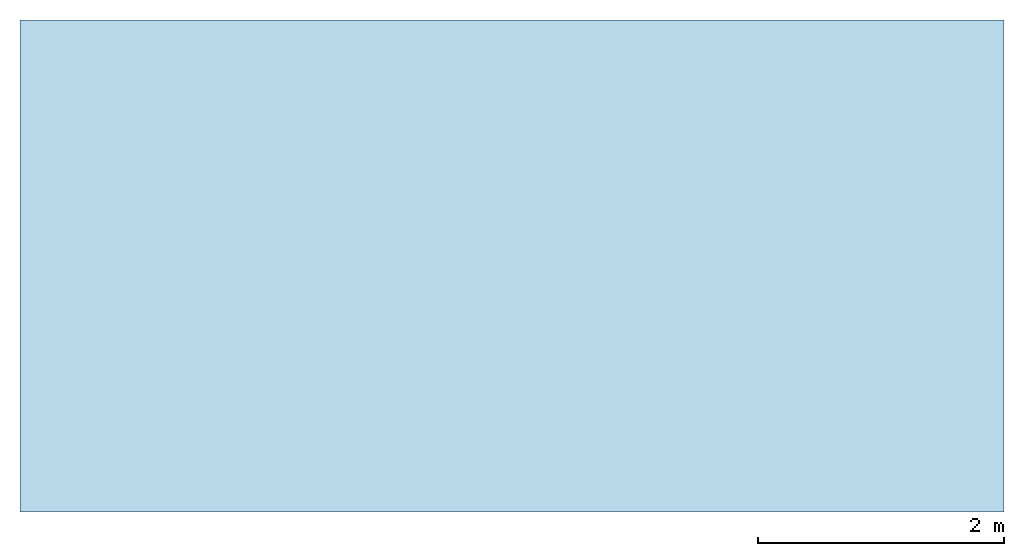
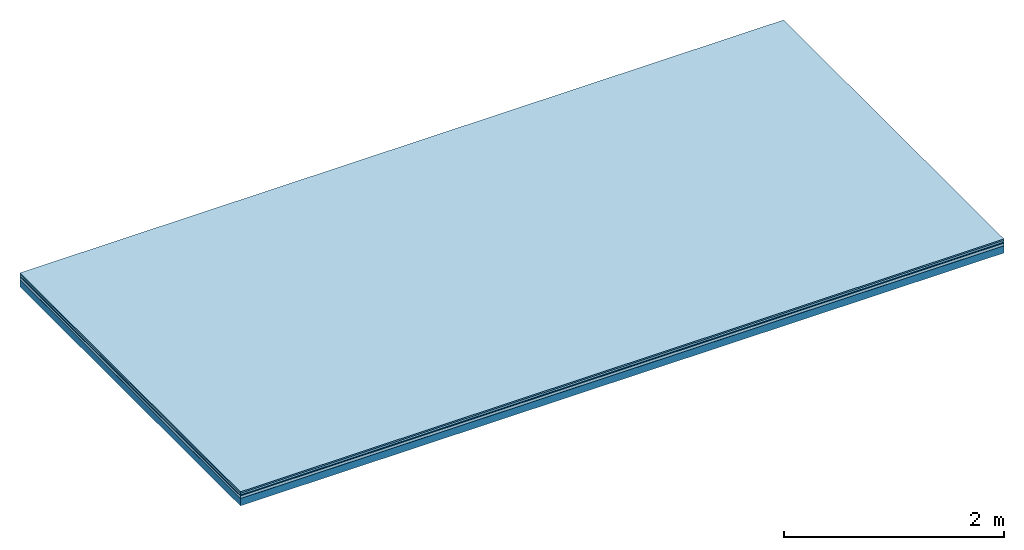
# One storey: 5 plates, 1 member, 1 element without a shape of its own.
"""IFC4 building model written with IfcOpenShell, lengths in metres."""

from ifc_helpers import new_model, si_unit, derived_unit, direction, frame, frame_2d, origin, origin_with_axes, place, context, project, spatial, rectangle, extrude, material, layer, layer_set, type_object, element, aggregate, save


model = new_model("IFC4")

# Units and contexts
plan_context = context("Plan", 3, precision=1e-05, world=origin(), true_north=direction((0.0, 1.0)))
model_context = context("Model", 3, precision=1e-05, world=origin(), true_north=direction((0.0, 1.0)))
ifc_project = project(units=[si_unit("LENGTHUNIT", "METRE"), derived_unit("SOUNDPRESSUREUNIT", [(si_unit("PRESSUREUNIT", "PASCAL", prefix="MICRO"), 0)]), si_unit("ENERGYUNIT", "JOULE", prefix="MEGA"), si_unit("MASSUNIT", "GRAM", prefix="KILO"), derived_unit("THERMALTRANSMITTANCEUNIT", [(si_unit("POWERUNIT", "WATT"), 1), (si_unit("AREAUNIT", "SQUARE_METRE"), -1), (si_unit("THERMODYNAMICTEMPERATUREUNIT", "KELVIN"), -1)]), derived_unit("AREADENSITYUNIT", [(si_unit("MASSUNIT", "GRAM", prefix="KILO"), 1), (si_unit("AREAUNIT", "SQUARE_METRE"), -1)]), derived_unit("USERDEFINED", [(si_unit("ENERGYUNIT", "JOULE", prefix="MEGA"), 1), (si_unit("AREAUNIT", "SQUARE_METRE"), -1)])], contexts=[plan_context, model_context])

# Site, building, storey
site = spatial("IfcSite", under=ifc_project)
building_placement = place(None, origin())
building = spatial("IfcBuilding", under=site, at=building_placement)
storey_placement = place(building_placement, origin())
storey = spatial("IfcBuildingStorey", under=building, at=storey_placement)

# Slab, member, plates
ifc_material_1 = material(Category="11.013")
ifc_layer_1 = layer(ifc_material_1, 0.015, Name="Flooring")
ifc_material_2 = material(Category="03.007")
ifc_layer_2 = layer(ifc_material_2, 0.02, Name="On-material")
ifc_material_3 = material(Name="Wood fiber generic product", Category="10.009")
ifc_layer_3 = layer(ifc_material_3, 0.01, Name="Impact sound insulation")
ifc_material_4 = material(Name="with broken")
ifc_layer_4 = layer(ifc_material_4, 0.03, Name="on Supporting structure")
ifc_material_5 = material(Name="protection", Category="09.007")
ifc_layer_5 = layer(ifc_material_5, 0.0005, Name="Sub-floor")
ifc_material_6 = material(Name="no composite action")
ifc_layer_6 = layer(ifc_material_6, 0.0, Name="Bond")
ifc_layer_7 = layer(None, 0.08, Name="Supporting structure")
ifc_layer_set = layer_set([ifc_layer_1, ifc_layer_2, ifc_layer_3, ifc_layer_4, ifc_layer_5, ifc_layer_6, ifc_layer_7])
slab_type = type_object("IfcSlabType", Name="A2040", PredefinedType="NOTDEFINED", material=ifc_layer_set)
slab_placement = place(None, frame((0.0, 0.0, 0.0), z_axis=(0.0, 0.0, -1.0), x_axis=(1.0, 0.0, 0.0)))
slab = element("IfcSlab", 1, at=slab_placement, inside=storey, type_object=slab_type, material=ifc_layer_set, Name="Slab #1")
ifc_material_7 = material(Name="Solid timber panel")
member_placement = place(slab_placement, origin())
member = element("IfcMember", 2, at=member_placement, material=ifc_material_7, Name="Supporting structure", context=plan_context, shape_type="SweptSolid", body=[
    extrude(rectangle(XDim=1.0, YDim=0.08, at=frame_2d((0.5, 0.04), x_axis=(1.0, 0.0))), frame((0.0, 4.0, 0.0755), z_axis=(0.0, -1.0, 0.0), x_axis=(1.0, 0.0, 0.0)), (0.0, 0.0, 1.0), 4.0),
    extrude(rectangle(XDim=1.0, YDim=0.08, at=frame_2d((0.5, 0.04), x_axis=(1.0, 0.0))), frame((1.0, 4.0, 0.0755), z_axis=(0.0, -1.0, 0.0), x_axis=(1.0, 0.0, 0.0)), (0.0, 0.0, 1.0), 4.0),
    extrude(rectangle(XDim=1.0, YDim=0.08, at=frame_2d((0.5, 0.04), x_axis=(1.0, 0.0))), frame((2.0, 4.0, 0.0755), z_axis=(0.0, -1.0, 0.0), x_axis=(1.0, 0.0, 0.0)), (0.0, 0.0, 1.0), 4.0),
    extrude(rectangle(XDim=1.0, YDim=0.08, at=frame_2d((0.5, 0.04), x_axis=(1.0, 0.0))), frame((3.0, 4.0, 0.0755), z_axis=(0.0, -1.0, 0.0), x_axis=(1.0, 0.0, 0.0)), (0.0, 0.0, 1.0), 4.0),
    extrude(rectangle(XDim=1.0, YDim=0.08, at=frame_2d((0.5, 0.04), x_axis=(1.0, 0.0))), frame((4.0, 4.0, 0.0755), z_axis=(0.0, -1.0, 0.0), x_axis=(1.0, 0.0, 0.0)), (0.0, 0.0, 1.0), 4.0),
    extrude(rectangle(XDim=1.0, YDim=0.08, at=frame_2d((0.5, 0.04), x_axis=(1.0, 0.0))), frame((5.0, 4.0, 0.0755), z_axis=(0.0, -1.0, 0.0), x_axis=(1.0, 0.0, 0.0)), (0.0, 0.0, 1.0), 4.0),
    extrude(rectangle(XDim=1.0, YDim=0.08, at=frame_2d((0.5, 0.04), x_axis=(1.0, 0.0))), frame((6.0, 4.0, 0.0755), z_axis=(0.0, -1.0, 0.0), x_axis=(1.0, 0.0, 0.0)), (0.0, 0.0, 1.0), 4.0),
    extrude(rectangle(XDim=1.0, YDim=0.08, at=frame_2d((0.5, 0.04), x_axis=(1.0, 0.0))), frame((7.0, 4.0, 0.0755), z_axis=(0.0, -1.0, 0.0), x_axis=(1.0, 0.0, 0.0)), (0.0, 0.0, 1.0), 4.0),
])
plate_1_placement = place(slab_placement, origin())
plate_1 = element("IfcPlate", 3, at=plate_1_placement, material=ifc_material_1, Name="Flooring", context=plan_context, shape_type="SweptSolid", body=[
    extrude(rectangle(XDim=8.0, YDim=4.0, at=frame_2d((4.0, 2.0), x_axis=(1.0, 0.0))), origin_with_axes(), (0.0, 0.0, 1.0), 0.015),
])
plate_2_placement = place(slab_placement, origin())
plate_2 = element("IfcPlate", 4, at=plate_2_placement, material=ifc_material_2, Name="On-material", context=plan_context, shape_type="SweptSolid", body=[
    extrude(rectangle(XDim=8.0, YDim=4.0, at=frame_2d((4.0, 2.0), x_axis=(1.0, 0.0))), frame((0.0, 0.0, 0.015), z_axis=(0.0, 0.0, 1.0), x_axis=(1.0, 0.0, 0.0)), (0.0, 0.0, 1.0), 0.02),
])
plate_3_placement = place(slab_placement, origin())
plate_3 = element("IfcPlate", 5, at=plate_3_placement, material=ifc_material_3, Name="Impact sound insulation", context=plan_context, shape_type="SweptSolid", body=[
    extrude(rectangle(XDim=8.0, YDim=4.0, at=frame_2d((4.0, 2.0), x_axis=(1.0, 0.0))), frame((0.0, 0.0, 0.035), z_axis=(0.0, 0.0, 1.0), x_axis=(1.0, 0.0, 0.0)), (0.0, 0.0, 1.0), 0.01),
])
plate_4_placement = place(slab_placement, origin())
plate_4 = element("IfcPlate", 6, at=plate_4_placement, material=ifc_material_4, Name="on Supporting structure", context=plan_context, shape_type="SweptSolid", body=[
    extrude(rectangle(XDim=8.0, YDim=4.0, at=frame_2d((4.0, 2.0), x_axis=(1.0, 0.0))), frame((0.0, 0.0, 0.045), z_axis=(0.0, 0.0, 1.0), x_axis=(1.0, 0.0, 0.0)), (0.0, 0.0, 1.0), 0.03),
])
plate_5_placement = place(slab_placement, origin())
plate_5 = element("IfcPlate", 7, at=plate_5_placement, material=ifc_material_5, Name="Sub-floor", context=plan_context, shape_type="SweptSolid", body=[
    extrude(rectangle(XDim=8.0, YDim=4.0, at=frame_2d((4.0, 2.0), x_axis=(1.0, 0.0))), frame((0.0, 0.0, 0.075), z_axis=(0.0, 0.0, 1.0), x_axis=(1.0, 0.0, 0.0)), (0.0, 0.0, 1.0), 0.0005),
])
aggregate(slab, [plate_1, plate_2, plate_3, plate_4, plate_5, member])

save(model, "model.ifc")
